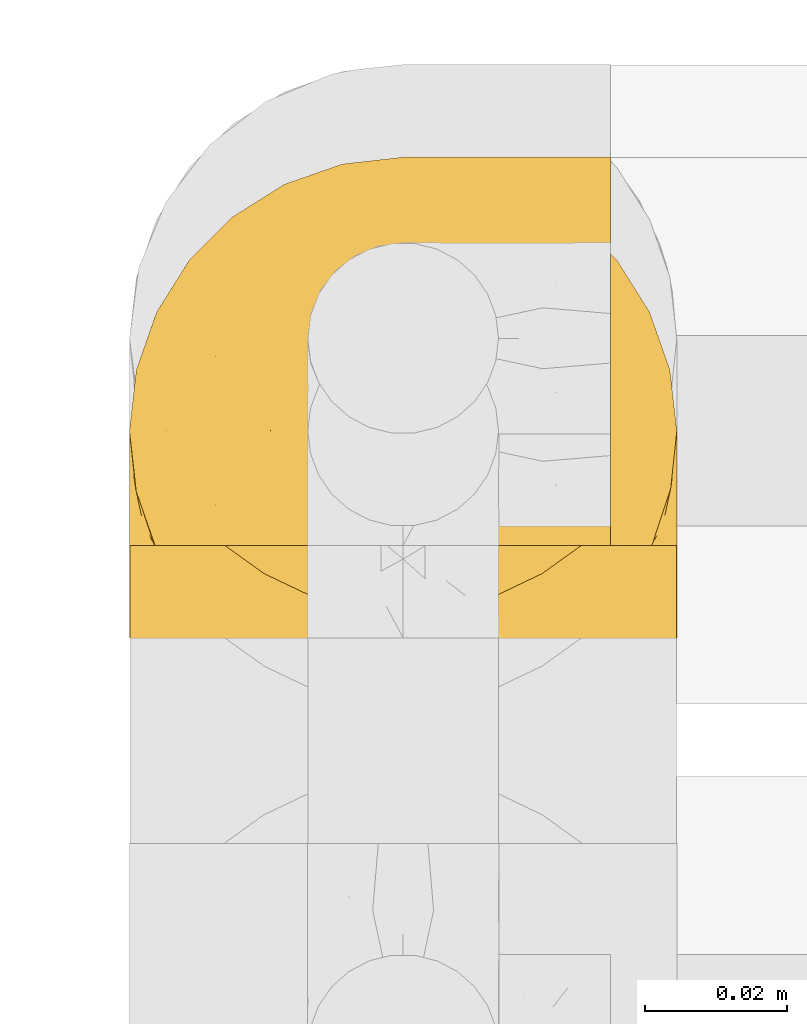
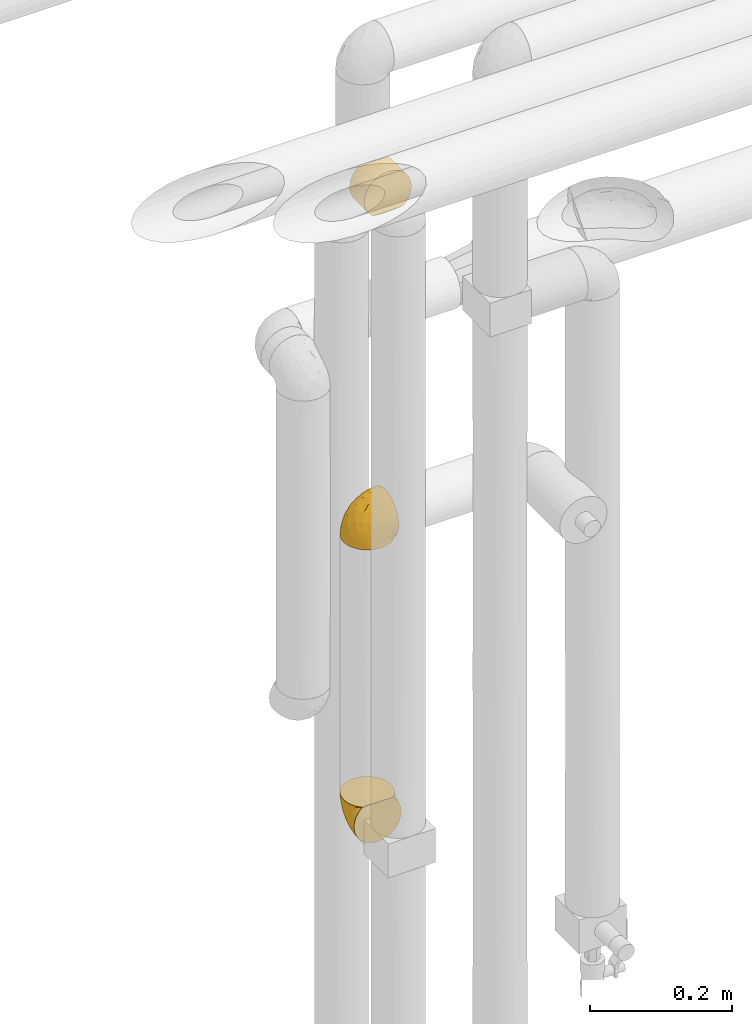
# One storey, part 327 of 827: 3 coverings.
"""IFC2X3 building model written with IfcOpenShell, lengths in millimetres."""

from ifc_helpers import new_model, entity, si_unit, converted_unit, derived_unit, direction, frame, origin, place, context, subcontext, project, spatial, faceted_brep, element, save


model = new_model("IFC2X3")

# Units and contexts
model_context = context("Model", 3, precision=0.01, world=origin(), true_north=direction((6.12303176911189e-17, 1.0)))
body_context = subcontext(model_context, "Body", "Model", "MODEL_VIEW")
ifc_project = project(units=[si_unit("LENGTHUNIT", "METRE", prefix="MILLI"), si_unit("AREAUNIT", "SQUARE_METRE"), si_unit("VOLUMEUNIT", "CUBIC_METRE"), converted_unit("PLANEANGLEUNIT", "DEGREE", entity("IfcRatioMeasure", 0.0174532925199433), si_unit("PLANEANGLEUNIT", "RADIAN"), dimensions=[0, 0, 0, 0, 0, 0, 0]), si_unit("MASSUNIT", "GRAM", prefix="KILO"), derived_unit("MASSDENSITYUNIT", [(si_unit("MASSUNIT", "GRAM", prefix="KILO"), 1), (si_unit("LENGTHUNIT", "METRE"), -3)]), derived_unit("MOMENTOFINERTIAUNIT", [(si_unit("LENGTHUNIT", "METRE"), 4)]), si_unit("TIMEUNIT", "SECOND"), si_unit("FREQUENCYUNIT", "HERTZ"), si_unit("THERMODYNAMICTEMPERATUREUNIT", "DEGREE_CELSIUS"), derived_unit("THERMALTRANSMITTANCEUNIT", [(si_unit("MASSUNIT", "GRAM", prefix="KILO"), 1), (si_unit("THERMODYNAMICTEMPERATUREUNIT", "KELVIN"), -1), (si_unit("TIMEUNIT", "SECOND"), -3)]), derived_unit("VOLUMETRICFLOWRATEUNIT", [(si_unit("LENGTHUNIT", "METRE"), 3), (si_unit("TIMEUNIT", "SECOND"), -1)]), derived_unit("MASSFLOWRATEUNIT", [(si_unit("MASSUNIT", "GRAM", prefix="KILO"), 1), (si_unit("TIMEUNIT", "SECOND"), -1)]), derived_unit("ROTATIONALFREQUENCYUNIT", [(si_unit("TIMEUNIT", "SECOND"), -1)]), si_unit("ELECTRICCURRENTUNIT", "AMPERE"), si_unit("ELECTRICVOLTAGEUNIT", "VOLT"), si_unit("POWERUNIT", "WATT"), si_unit("FORCEUNIT", "NEWTON", prefix="KILO"), si_unit("ILLUMINANCEUNIT", "LUX"), si_unit("LUMINOUSFLUXUNIT", "LUMEN"), si_unit("LUMINOUSINTENSITYUNIT", "CANDELA"), derived_unit("USERDEFINED", [(si_unit("MASSUNIT", "GRAM", prefix="KILO"), -1), (si_unit("LENGTHUNIT", "METRE"), -2), (si_unit("TIMEUNIT", "SECOND"), 3), (si_unit("LUMINOUSFLUXUNIT", "LUMEN"), 1)]), derived_unit("LINEARVELOCITYUNIT", [(si_unit("LENGTHUNIT", "METRE"), 1), (si_unit("TIMEUNIT", "SECOND"), -1)]), si_unit("PRESSUREUNIT", "PASCAL"), derived_unit("USERDEFINED", [(si_unit("LENGTHUNIT", "METRE"), -2), (si_unit("MASSUNIT", "GRAM", prefix="KILO"), 1), (si_unit("TIMEUNIT", "SECOND"), -2)]), derived_unit("LINEARFORCEUNIT", [(si_unit("MASSUNIT", "GRAM", prefix="KILO"), 1), (si_unit("LENGTHUNIT", "METRE"), 1), (si_unit("TIMEUNIT", "SECOND"), -2), (si_unit("LENGTHUNIT", "METRE"), -1)]), derived_unit("PLANARFORCEUNIT", [(si_unit("MASSUNIT", "GRAM", prefix="KILO"), 1), (si_unit("LENGTHUNIT", "METRE"), 1), (si_unit("TIMEUNIT", "SECOND"), -2), (si_unit("LENGTHUNIT", "METRE"), -2)])], contexts=[model_context])

# Site, building, storey
site_placement = place(None, origin())
site = spatial("IfcSite", under=ifc_project, at=site_placement, CompositionType="ELEMENT")
building_placement = place(site_placement, origin())
building = spatial("IfcBuilding", under=site, at=building_placement, CompositionType="ELEMENT")
storey_placement = place(building_placement, frame((0.0, 0.0, 28200.0)))
storey = spatial("IfcBuildingStorey", under=building, at=storey_placement, Name="08", CompositionType="ELEMENT", Elevation=28200.0)

# Coverings
covering_1_placement = place(storey_placement, frame((34485.34, 18381.86, 2179.3)))
element("IfcCovering", 1, at=covering_1_placement, inside=storey, Name=":ADSK_", ObjectType=":ADSK_", PredefinedType="INSULATION", context=body_context, shape_type="Brep", body=[
    faceted_brep([(23.36, 5.41, 1.6), (16.07, 9.99, 1.6), (9.98, 16.08, 1.6), (5.4, 23.37, 1.6), (2.56, 31.49, 1.6), (1.6, 40.05, 1.6), (2.56, 48.61, 1.6), (5.41, 56.73, 1.6), (9.99, 64.02, 1.6), (16.08, 70.11, 1.6), (23.37, 74.69, 1.6), (31.49, 77.53, 1.6), (40.05, 78.5, 1.6), (48.15, 77.63, 1.6), (55.88, 75.08, 1.6), (62.9, 70.97, 1.6), (68.89, 65.47, 1.6), (68.89, 63.27, 1.6), (68.89, 61.53, 1.6), (68.89, 59.57, 1.6), (68.89, 57.6, 1.6), (68.89, 55.63, 1.6), (68.89, 53.67, 1.6), (68.89, 51.7, 1.6), (68.89, 49.73, 1.6), (68.89, 47.54, 1.6), (68.89, 45.34, 1.6), (68.89, 43.15, 1.6), (68.89, 40.96, 1.6), (68.89, 38.76, 1.6), (68.89, 36.57, 1.6), (68.89, 34.37, 1.6), (68.89, 32.18, 1.6), (68.89, 29.98, 1.6), (68.89, 27.79, 1.6), (68.89, 25.6, 1.6), (68.89, 23.4, 1.6), (68.89, 21.21, 1.6), (68.89, 19.01, 1.6), (68.89, 16.82, 1.6), (68.89, 14.62, 1.6), (62.89, 9.12, 1.6), (55.86, 5.0, 1.6), (48.13, 2.46, 1.6), (40.05, 1.6, 1.6), (31.49, 2.56, 1.6), (69.15, 65.47, 1.85), (69.15, 70.97, 7.85), (69.15, 75.09, 14.87), (69.15, 77.63, 22.6), (69.15, 78.5, 30.7), (69.15, 77.19, 40.65), (69.15, 73.34, 49.92), (69.15, 67.23, 57.88), (69.15, 59.27, 63.99), (69.15, 50.0, 67.84), (69.15, 40.05, 69.15), (69.15, 30.09, 67.84), (69.15, 20.82, 63.99), (69.15, 12.86, 57.88), (69.15, 6.75, 49.92), (69.15, 2.91, 40.65), (69.15, 1.6, 30.7), (69.15, 2.46, 22.6), (69.15, 5.0, 14.87), (69.15, 9.12, 7.85), (69.15, 14.62, 1.85), (69.15, 16.82, 1.85), (69.15, 17.8, 1.85), (69.15, 19.39, 1.85), (69.15, 20.98, 1.85), (69.15, 22.57, 1.85), (69.15, 24.16, 1.85), (69.15, 25.75, 1.85), (69.15, 27.33, 1.85), (69.15, 28.92, 1.85), (69.15, 30.51, 1.85), (69.15, 32.1, 1.85), (69.15, 33.69, 1.85), (69.15, 35.28, 1.85), (69.15, 36.87, 1.85), (69.15, 38.46, 1.85), (69.15, 40.05, 1.85), (69.15, 41.63, 1.85), (69.15, 43.22, 1.85), (69.15, 44.81, 1.85), (69.15, 46.4, 1.85), (69.15, 47.99, 1.85), (69.15, 49.58, 1.85), (69.15, 51.17, 1.85), (69.15, 52.76, 1.85), (69.15, 54.72, 1.85), (69.15, 56.69, 1.85), (69.15, 58.88, 1.85), (69.15, 61.08, 1.85), (69.15, 63.27, 1.85), (68.96, 37.77, 1.77), (68.97, 36.07, 1.78), (68.97, 32.96, 1.77), (68.97, 31.36, 1.77), (68.95, 56.52, 1.76), (68.96, 54.96, 1.77), (68.98, 18.75, 1.79), (68.97, 58.07, 1.78), (68.97, 50.37, 1.78), (68.98, 23.36, 1.78), (68.97, 24.95, 1.78), (68.97, 42.43, 1.78), (68.94, 15.97, 1.74), (68.98, 51.96, 1.78), (68.98, 53.47, 1.78), (68.96, 48.63, 1.77), (68.97, 63.93, 1.78), (68.98, 40.93, 1.78), (68.98, 29.72, 1.78), (68.97, 62.4, 1.77), (68.96, 60.92, 1.77), (68.97, 17.31, 1.77), (68.97, 21.74, 1.78), (68.98, 34.56, 1.78), (68.96, 20.18, 1.77), (68.97, 14.62, 1.77), (68.94, 14.62, 1.72), (68.92, 14.62, 1.66), (68.97, 65.47, 1.77), (69.02, 65.47, 1.8), (69.08, 65.47, 1.82), (68.98, 59.5, 1.79), (68.97, 47.1, 1.78), (68.98, 45.61, 1.79), (68.97, 28.18, 1.78), (69.08, 14.62, 1.82), (69.02, 14.62, 1.8), (68.96, 26.61, 1.76), (68.92, 65.47, 1.66), (68.94, 65.47, 1.72), (68.97, 39.32, 1.78), (68.96, 44.12, 1.77), (67.02, 72.26, 9.41), (63.33, 76.57, 17.65), (64.61, 71.77, 7.41), (49.27, 78.5, 21.47), (51.4, 77.9, 15.21), (43.94, 78.5, 16.15), (61.87, 78.5, 28.75), (61.54, 75.52, 13.67), (57.95, 76.13, 12.79), (56.12, 77.81, 19.18), (65.41, 72.4, 9.04), (53.1, 76.56, 7.41), (63.04, 71.77, 5.74), (61.33, 72.25, 3.72), (41.99, 78.5, 8.87), (54.6, 78.5, 26.8), (56.6, 75.75, 9.53), (41.58, 78.5, 7.34), (61.54, 75.57, 44.74), (28.67, 76.34, 12.03), (58.75, 77.64, 37.26), (46.12, 63.45, 56.57), (55.56, 70.55, 52.31), (42.09, 71.02, 45.87), (17.15, 66.15, 25.73), (12.68, 60.51, 26.34), (20.17, 63.72, 35.21), (52.38, 75.57, 42.07), (23.76, 72.61, 21.49), (34.7, 76.83, 22.52), (20.5, 72.61, 11.02), (14.64, 67.24, 15.64), (49.4, 47.19, 65.49), (52.34, 54.76, 63.99), (58.67, 63.45, 60.27), (5.82, 52.75, 17.92), (30.64, 53.89, 53.93), (26.66, 46.73, 53.36), (37.53, 48.67, 60.18), (41.11, 55.34, 59.54), (21.38, 40.05, 49.36), (13.72, 50.46, 37.63), (6.74, 40.05, 27.45), (14.06, 40.05, 38.4), (41.77, 77.74, 26.02), (51.58, 77.66, 34.22), (16.28, 57.43, 36.59), (4.3, 40.05, 15.2), (8.62, 60.51, 13.32), (25.26, 60.1, 45.25), (21.47, 51.88, 46.78), (33.37, 72.59, 35.9), (41.35, 76.05, 33.87), (55.54, 40.05, 66.44), (35.17, 63.95, 50.09), (29.04, 67.24, 41.08), (24.34, 69.62, 31.14), (29.33, 73.6, 28.19), (43.3, 40.05, 64.0), (32.34, 40.05, 56.68), (49.41, 32.72, 65.46), (41.58, 1.6, 7.34), (28.66, 3.75, 12.03), (13.7, 29.63, 37.61), (27.85, 27.18, 52.22), (5.82, 27.35, 17.91), (12.67, 19.59, 26.34), (19.45, 12.86, 28.05), (14.63, 12.86, 15.64), (23.75, 7.49, 21.48), (48.85, 9.54, 50.02), (54.13, 16.64, 59.28), (37.84, 17.48, 53.05), (55.15, 2.33, 35.39), (54.6, 1.6, 26.8), (61.87, 1.6, 28.75), (37.91, 8.17, 41.4), (50.18, 4.3, 40.48), (57.58, 26.94, 65.81), (20.83, 20.75, 41.02), (59.91, 9.54, 53.28), (57.75, 4.52, 43.9), (20.49, 7.49, 11.01), (41.99, 1.6, 8.87), (43.94, 1.6, 16.15), (8.61, 19.59, 13.31), (34.7, 3.27, 22.54), (42.64, 2.45, 27.68), (49.27, 1.6, 21.47), (36.94, 31.21, 59.8), (45.72, 25.33, 61.82), (62.29, 2.29, 37.3), (29.01, 12.86, 41.07), (31.47, 6.89, 32.24), (49.29, 2.23, 31.68), (37.18, 12.43, 47.4), (43.45, 4.1, 35.77), (63.33, 3.53, 17.65), (67.23, 6.88, 11.06), (66.07, 8.16, 8.55), (65.22, 9.02, 6.63), (61.99, 5.0, 12.77), (57.95, 3.96, 12.79), (53.09, 3.52, 7.41), (56.84, 2.4, 18.97), (61.33, 7.83, 3.72), (63.06, 8.32, 5.76), (51.41, 2.19, 15.21), (56.61, 4.34, 9.52)], [[[0, 1, 2, 3, 4, 5, 6, 7, 8, 9, 10, 11, 12, 13, 14, 15, 16, 17, 18, 19, 20, 21, 22, 23, 24, 25, 26, 27, 28, 29, 30, 31, 32, 33, 34, 35, 36, 37, 38, 39, 40, 41, 42, 43, 44, 45]], [[46, 47, 48, 49, 50, 51, 52, 53, 54, 55, 56, 57, 58, 59, 60, 61, 62, 63, 64, 65, 66, 67, 68, 69, 70, 71, 72, 73, 74, 75, 76, 77, 78, 79, 80, 81, 82, 83, 84, 85, 86, 87, 88, 89, 90, 91, 92, 93, 94, 95]], [[96, 97, 30]], [[98, 77, 99]], [[100, 101, 21]], [[69, 68, 102]], [[20, 19, 103]], [[24, 23, 104]], [[20, 103, 100]], [[72, 105, 106]], [[84, 83, 107]], [[89, 88, 104]], [[108, 67, 66]], [[109, 110, 90]], [[111, 25, 24]], [[112, 17, 16]], [[82, 113, 83]], [[109, 23, 22]], [[114, 76, 75]], [[105, 36, 106]], [[104, 111, 24]], [[18, 115, 116]], [[97, 96, 80]], [[67, 108, 117]], [[105, 71, 118]], [[31, 97, 119]], [[102, 120, 69]], [[108, 121, 122, 123, 40]], [[112, 95, 115]], [[17, 115, 18]], [[94, 116, 115]], [[117, 68, 67]], [[38, 117, 39]], [[112, 124, 125, 126, 46]], [[17, 112, 115]], [[70, 120, 118]], [[39, 117, 108]], [[120, 38, 37]], [[120, 37, 118]], [[120, 70, 69]], [[116, 94, 127]], [[128, 86, 129]], [[117, 38, 102]], [[74, 130, 75]], [[99, 33, 32]], [[115, 95, 94]], [[39, 108, 40]], [[108, 66, 131, 132, 121]], [[105, 72, 71]], [[118, 37, 36]], [[71, 70, 118]], [[35, 106, 36]], [[36, 105, 118]], [[35, 133, 106]], [[74, 73, 133]], [[106, 133, 73]], [[99, 114, 33]], [[133, 35, 34]], [[73, 72, 106]], [[95, 112, 46]], [[112, 16, 134, 135, 124]], [[130, 114, 75]], [[99, 76, 114]], [[114, 130, 33]], [[34, 33, 130]], [[78, 77, 98]], [[98, 119, 78]], [[130, 133, 34]], [[133, 130, 74]], [[79, 97, 80]], [[98, 99, 32]], [[98, 32, 31]], [[77, 76, 99]], [[97, 79, 119]], [[136, 96, 29]], [[30, 97, 31]], [[136, 29, 28]], [[81, 80, 96]], [[29, 96, 30]], [[31, 119, 98]], [[119, 79, 78]], [[96, 136, 81]], [[82, 81, 136]], [[113, 107, 83]], [[84, 107, 137]], [[107, 27, 137]], [[113, 28, 107]], [[27, 107, 28]], [[85, 84, 137]], [[137, 27, 26]], [[113, 136, 28]], [[136, 113, 82]], [[109, 89, 104]], [[86, 85, 129]], [[89, 109, 90]], [[111, 87, 128]], [[26, 129, 137]], [[88, 111, 104]], [[25, 111, 128]], [[22, 110, 109]], [[23, 109, 104]], [[110, 91, 90]], [[100, 92, 101]], [[110, 22, 101]], [[91, 110, 101]], [[116, 19, 18]], [[111, 88, 87]], [[127, 103, 19]], [[25, 128, 26]], [[86, 128, 87]], [[128, 129, 26]], [[137, 129, 85]], [[120, 102, 38]], [[117, 102, 68]], [[91, 101, 92]], [[21, 101, 22]], [[93, 92, 103]], [[100, 21, 20]], [[100, 103, 92]], [[127, 93, 103]], [[93, 127, 94]], [[116, 127, 19]], [[126, 138, 47]], [[48, 138, 139]], [[140, 125, 124]], [[141, 142, 143]], [[144, 49, 139]], [[145, 140, 146]], [[48, 139, 49]], [[139, 145, 147]], [[144, 50, 49]], [[126, 125, 148]], [[14, 13, 149]], [[150, 146, 140]], [[148, 140, 145]], [[151, 150, 135]], [[151, 14, 149]], [[16, 15, 134]], [[13, 152, 149]], [[124, 150, 140]], [[141, 147, 142]], [[14, 151, 15]], [[15, 151, 134]], [[47, 46, 126]], [[139, 153, 144]], [[138, 48, 47]], [[125, 140, 148]], [[135, 134, 151]], [[146, 154, 142]], [[145, 146, 147]], [[148, 139, 138]], [[147, 141, 153]], [[147, 146, 142]], [[139, 147, 153]], [[139, 148, 145]], [[148, 138, 126]], [[154, 146, 150]], [[149, 143, 142]], [[151, 154, 150]], [[149, 142, 154]], [[13, 12, 155, 152]], [[152, 143, 149]], [[151, 149, 154]], [[150, 124, 135]], [[51, 156, 52]], [[155, 11, 157]], [[50, 144, 158]], [[159, 160, 161]], [[162, 163, 164]], [[158, 165, 156]], [[157, 166, 167]], [[166, 168, 169]], [[170, 55, 171]], [[161, 160, 165]], [[172, 54, 53]], [[160, 53, 52]], [[173, 7, 6]], [[54, 172, 171]], [[174, 175, 176]], [[170, 177, 176]], [[167, 143, 157]], [[178, 179, 180, 181]], [[157, 11, 10]], [[141, 182, 183]], [[160, 52, 156]], [[173, 179, 184]], [[8, 169, 9]], [[173, 6, 185]], [[155, 12, 11]], [[8, 7, 186]], [[162, 169, 163]], [[187, 184, 188]], [[180, 173, 185]], [[10, 168, 157]], [[54, 171, 55]], [[186, 173, 163]], [[157, 143, 152, 155]], [[189, 161, 190]], [[179, 173, 180]], [[9, 168, 10]], [[186, 169, 8]], [[187, 164, 184]], [[144, 183, 158]], [[172, 160, 159]], [[177, 174, 176]], [[55, 170, 191]], [[187, 192, 193]], [[183, 182, 190]], [[166, 194, 195]], [[167, 190, 182]], [[6, 5, 185]], [[173, 186, 7]], [[169, 186, 163]], [[169, 168, 9]], [[157, 168, 166]], [[190, 161, 165]], [[161, 193, 192]], [[183, 165, 158]], [[194, 189, 195]], [[191, 170, 196]], [[191, 56, 55]], [[175, 178, 197]], [[197, 196, 176]], [[170, 176, 196]], [[188, 175, 174]], [[197, 176, 175]], [[177, 170, 171]], [[171, 159, 177]], [[192, 177, 159]], [[187, 188, 174]], [[188, 179, 178]], [[174, 177, 192]], [[164, 187, 193]], [[174, 192, 187]], [[161, 192, 159]], [[194, 164, 193]], [[184, 164, 163]], [[189, 194, 193]], [[162, 166, 169]], [[161, 189, 193]], [[195, 190, 167]], [[173, 184, 163]], [[184, 179, 188]], [[164, 194, 162]], [[166, 162, 194]], [[190, 195, 189]], [[167, 182, 143]], [[167, 166, 195]], [[160, 172, 53]], [[171, 172, 159]], [[51, 50, 158]], [[160, 156, 165]], [[51, 158, 156]], [[183, 144, 153]], [[141, 183, 153]], [[190, 165, 183]], [[178, 175, 188]], [[143, 182, 141]], [[198, 191, 196]], [[45, 199, 200]], [[178, 201, 202]], [[201, 203, 204]], [[205, 206, 207]], [[57, 56, 191]], [[4, 185, 5]], [[208, 209, 210]], [[211, 212, 213]], [[208, 214, 215]], [[216, 209, 58]], [[201, 217, 202]], [[59, 218, 60]], [[60, 218, 219]], [[201, 178, 181, 180]], [[1, 0, 220]], [[201, 180, 203]], [[200, 199, 221, 222]], [[203, 185, 4]], [[3, 203, 4]], [[2, 1, 206]], [[217, 210, 202]], [[58, 209, 59]], [[3, 223, 203]], [[207, 220, 200]], [[204, 223, 206]], [[205, 204, 206]], [[207, 200, 224]], [[200, 222, 224]], [[206, 223, 2]], [[225, 222, 226]], [[220, 206, 1]], [[60, 219, 61]], [[57, 198, 216]], [[227, 202, 228]], [[3, 2, 223]], [[45, 44, 199]], [[0, 45, 200]], [[219, 211, 229]], [[230, 231, 214]], [[231, 207, 224]], [[210, 209, 228]], [[218, 209, 208]], [[226, 232, 225]], [[231, 230, 205]], [[202, 210, 228]], [[233, 230, 214]], [[227, 228, 198]], [[201, 204, 217]], [[211, 232, 212]], [[180, 185, 203]], [[61, 229, 62]], [[203, 223, 204]], [[200, 220, 0]], [[206, 220, 207]], [[225, 231, 224]], [[232, 226, 212]], [[214, 231, 234]], [[197, 227, 196]], [[191, 198, 57]], [[198, 228, 216]], [[202, 197, 178]], [[196, 227, 198]], [[197, 202, 227]], [[209, 216, 228]], [[58, 57, 216]], [[229, 211, 213]], [[215, 211, 219]], [[205, 217, 204]], [[210, 217, 230]], [[62, 229, 213]], [[219, 229, 61]], [[231, 205, 207]], [[217, 205, 230]], [[215, 214, 234]], [[233, 208, 210]], [[209, 218, 59]], [[219, 218, 208]], [[208, 215, 219]], [[232, 215, 234]], [[215, 232, 211]], [[232, 234, 225]], [[231, 225, 234]], [[222, 225, 224]], [[208, 233, 214]], [[210, 230, 233]], [[63, 213, 235]], [[213, 212, 235]], [[213, 63, 62]], [[236, 235, 237]], [[237, 132, 131]], [[235, 236, 64]], [[238, 239, 240]], [[63, 235, 64]], [[131, 66, 65]], [[236, 131, 65]], [[241, 221, 43]], [[236, 65, 64]], [[238, 121, 132]], [[42, 241, 43]], [[240, 239, 242]], [[41, 123, 243]], [[43, 221, 199, 44]], [[243, 122, 244]], [[226, 245, 242]], [[240, 242, 245]], [[121, 238, 244]], [[41, 40, 123]], [[132, 237, 238]], [[243, 42, 41]], [[131, 236, 237]], [[239, 238, 237]], [[244, 238, 240]], [[246, 240, 245]], [[246, 243, 244]], [[237, 235, 239]], [[242, 235, 212]], [[235, 242, 239]], [[222, 245, 226]], [[242, 212, 226]], [[222, 241, 245]], [[240, 246, 244]], [[245, 241, 246]], [[243, 246, 241]], [[241, 222, 221]], [[42, 243, 241]], [[122, 243, 123]], [[122, 121, 244]]]),
])
covering_2_placement = place(storey_placement, frame((34485.34, 18391.21, 1669.95)))
element("IfcCovering", 2, at=covering_2_placement, inside=storey, Name=":ADSK_", ObjectType=":ADSK_", PredefinedType="INSULATION", context=body_context, shape_type="Brep", body=[
    faceted_brep([(74.68, 47.38, 69.15), (70.1, 54.67, 69.15), (64.01, 60.76, 69.15), (56.72, 65.34, 69.15), (48.6, 68.18, 69.15), (40.05, 69.15, 69.15), (31.49, 68.18, 69.15), (23.36, 65.33, 69.15), (16.07, 60.75, 69.15), (9.98, 54.66, 69.15), (5.4, 47.37, 69.15), (2.56, 39.25, 69.15), (1.6, 30.7, 69.15), (2.46, 22.59, 69.15), (5.01, 14.86, 69.15), (9.13, 7.84, 69.15), (14.62, 1.85, 69.15), (16.82, 1.85, 69.15), (18.56, 1.85, 69.15), (20.52, 1.85, 69.15), (22.49, 1.85, 69.15), (24.46, 1.85, 69.15), (26.42, 1.85, 69.15), (28.39, 1.85, 69.15), (30.36, 1.85, 69.15), (32.55, 1.85, 69.15), (34.75, 1.85, 69.15), (36.94, 1.85, 69.15), (39.13, 1.85, 69.15), (41.33, 1.85, 69.15), (43.52, 1.85, 69.15), (45.72, 1.85, 69.15), (47.91, 1.85, 69.15), (50.11, 1.85, 69.15), (52.3, 1.85, 69.15), (54.49, 1.85, 69.15), (56.69, 1.85, 69.15), (58.88, 1.85, 69.15), (61.08, 1.85, 69.15), (63.27, 1.85, 69.15), (65.47, 1.85, 69.15), (70.97, 7.85, 69.15), (75.09, 14.88, 69.15), (77.64, 22.61, 69.15), (78.5, 30.7, 69.15), (77.53, 39.26, 69.15), (14.62, 1.6, 68.89), (9.12, 1.6, 62.89), (5.0, 1.6, 55.87), (2.46, 1.6, 48.14), (1.6, 1.6, 40.05), (2.91, 1.6, 30.09), (6.75, 1.6, 20.82), (12.86, 1.6, 12.86), (20.82, 1.6, 6.75), (30.09, 1.6, 2.91), (40.05, 1.6, 1.6), (50.0, 1.6, 2.91), (59.27, 1.6, 6.75), (67.23, 1.6, 12.86), (73.34, 1.6, 20.82), (77.19, 1.6, 30.09), (78.5, 1.6, 40.05), (77.63, 1.6, 48.14), (75.09, 1.6, 55.87), (70.97, 1.6, 62.89), (65.47, 1.6, 68.89), (63.27, 1.6, 68.89), (62.29, 1.6, 68.89), (60.7, 1.6, 68.89), (59.11, 1.6, 68.89), (57.52, 1.6, 68.89), (55.93, 1.6, 68.89), (54.34, 1.6, 68.89), (52.76, 1.6, 68.89), (51.17, 1.6, 68.89), (49.58, 1.6, 68.89), (47.99, 1.6, 68.89), (46.4, 1.6, 68.89), (44.81, 1.6, 68.89), (43.22, 1.6, 68.89), (41.63, 1.6, 68.89), (40.05, 1.6, 68.89), (38.46, 1.6, 68.89), (36.87, 1.6, 68.89), (35.28, 1.6, 68.89), (33.69, 1.6, 68.89), (32.1, 1.6, 68.89), (30.51, 1.6, 68.89), (28.92, 1.6, 68.89), (27.33, 1.6, 68.89), (25.37, 1.6, 68.89), (23.4, 1.6, 68.89), (21.21, 1.6, 68.89), (19.01, 1.6, 68.89), (16.82, 1.6, 68.89), (42.32, 1.78, 68.97), (44.02, 1.77, 68.96), (47.13, 1.78, 68.97), (48.74, 1.77, 68.97), (23.57, 1.79, 68.98), (25.13, 1.78, 68.97), (61.34, 1.76, 68.96), (22.02, 1.77, 68.96), (29.72, 1.77, 68.96), (56.73, 1.76, 68.96), (55.14, 1.77, 68.96), (37.66, 1.77, 68.96), (64.12, 1.8, 69.0), (28.13, 1.76, 68.96), (26.62, 1.77, 68.96), (31.46, 1.78, 68.97), (16.16, 1.77, 68.96), (39.16, 1.77, 68.96), (50.37, 1.76, 68.96), (17.69, 1.77, 68.97), (19.17, 1.78, 68.97), (62.78, 1.77, 68.97), (58.35, 1.77, 68.96), (45.53, 1.77, 68.96), (59.91, 1.78, 68.97), (65.47, 1.77, 68.97), (65.47, 1.8, 69.02), (65.47, 1.82, 69.08), (14.62, 1.77, 68.97), (14.62, 1.72, 68.94), (14.62, 1.66, 68.92), (20.59, 1.76, 68.96), (32.99, 1.77, 68.96), (34.48, 1.76, 68.95), (51.91, 1.77, 68.96), (65.47, 1.66, 68.92), (65.47, 1.72, 68.94), (53.48, 1.78, 68.98), (14.62, 1.82, 69.08), (14.62, 1.8, 69.02), (40.77, 1.77, 68.96), (35.97, 1.78, 68.97), (7.84, 3.72, 61.33), (3.53, 7.41, 53.1), (8.32, 6.13, 63.33), (1.6, 21.47, 49.27), (2.19, 19.34, 55.53), (1.6, 26.8, 54.6), (1.6, 8.87, 41.99), (4.57, 9.2, 57.07), (3.96, 12.79, 57.95), (2.28, 14.62, 51.56), (7.69, 5.33, 61.7), (3.53, 17.64, 63.33), (8.32, 7.7, 65.0), (7.84, 9.41, 67.02), (1.6, 28.75, 61.87), (1.6, 16.15, 43.94), (4.34, 14.14, 61.21), (1.6, 29.16, 63.4), (4.52, 9.2, 26.0), (3.75, 42.07, 58.71), (2.45, 11.99, 33.48), (16.64, 24.62, 14.17), (9.54, 15.19, 18.43), (9.07, 28.65, 24.87), (13.94, 53.59, 45.01), (19.58, 58.06, 44.4), (16.37, 50.57, 35.53), (4.52, 18.36, 28.67), (7.49, 46.98, 49.25), (3.26, 36.04, 48.22), (7.49, 50.24, 59.72), (12.85, 56.1, 55.1), (32.9, 21.34, 5.25), (25.33, 18.4, 6.75), (16.64, 12.07, 10.47), (27.34, 64.92, 52.82), (26.2, 40.1, 16.81), (33.36, 44.08, 17.38), (31.42, 33.21, 10.56), (24.75, 29.63, 11.2), (40.05, 49.36, 21.38), (29.63, 57.02, 33.11), (40.05, 64.0, 43.3), (40.05, 56.68, 32.34), (2.35, 28.97, 44.72), (2.43, 19.16, 36.52), (22.66, 54.46, 34.15), (40.05, 66.44, 55.54), (19.58, 62.12, 57.42), (19.99, 45.49, 25.49), (28.21, 49.27, 23.96), (7.5, 37.37, 34.84), (4.04, 29.39, 36.87), (40.05, 15.2, 4.3), (16.14, 35.57, 20.65), (12.85, 41.7, 29.66), (10.47, 46.4, 39.6), (6.49, 41.41, 42.55), (40.05, 27.45, 6.74), (40.05, 38.4, 14.06), (47.37, 21.33, 5.28), (78.5, 29.16, 63.4), (76.34, 42.08, 58.71), (50.46, 57.04, 33.13), (52.91, 42.89, 18.52), (52.74, 64.92, 52.83), (60.5, 58.07, 44.4), (67.23, 51.29, 42.69), (67.23, 56.11, 55.1), (72.6, 46.99, 49.26), (70.55, 21.89, 20.72), (63.45, 16.62, 11.46), (62.61, 32.9, 17.69), (77.76, 15.6, 35.35), (78.5, 16.15, 43.94), (78.5, 8.87, 41.99), (71.93, 32.83, 29.34), (75.79, 20.56, 30.26), (53.16, 13.16, 4.93), (59.34, 49.91, 29.72), (70.55, 10.83, 17.46), (75.57, 12.99, 26.84), (72.6, 50.25, 59.73), (78.5, 28.75, 61.87), (78.5, 26.8, 54.6), (60.5, 62.13, 57.43), (76.82, 36.04, 48.2), (77.64, 28.1, 43.06), (78.5, 21.47, 49.27), (48.88, 33.8, 10.94), (54.76, 25.02, 8.92), (77.8, 8.45, 33.44), (67.23, 41.73, 29.67), (73.2, 39.27, 38.5), (77.86, 21.46, 39.06), (67.66, 33.56, 23.35), (75.99, 27.29, 34.97), (76.57, 7.41, 53.1), (73.21, 3.51, 59.68), (71.93, 4.68, 62.19), (71.07, 5.52, 64.11), (75.09, 8.75, 57.97), (76.13, 12.79, 57.95), (76.57, 17.65, 63.33), (77.69, 13.9, 51.77), (72.26, 9.42, 67.02), (71.77, 7.68, 64.98), (77.9, 19.33, 55.53), (75.75, 14.13, 61.22)], [[[0, 1, 2, 3, 4, 5, 6, 7, 8, 9, 10, 11, 12, 13, 14, 15, 16, 17, 18, 19, 20, 21, 22, 23, 24, 25, 26, 27, 28, 29, 30, 31, 32, 33, 34, 35, 36, 37, 38, 39, 40, 41, 42, 43, 44, 45]], [[46, 47, 48, 49, 50, 51, 52, 53, 54, 55, 56, 57, 58, 59, 60, 61, 62, 63, 64, 65, 66, 67, 68, 69, 70, 71, 72, 73, 74, 75, 76, 77, 78, 79, 80, 81, 82, 83, 84, 85, 86, 87, 88, 89, 90, 91, 92, 93, 94, 95]], [[96, 97, 30]], [[98, 77, 99]], [[100, 101, 21]], [[69, 68, 102]], [[20, 19, 103]], [[24, 23, 104]], [[20, 103, 100]], [[72, 105, 106]], [[84, 83, 107]], [[89, 88, 104]], [[108, 67, 66]], [[109, 110, 90]], [[111, 25, 24]], [[112, 17, 16]], [[82, 113, 83]], [[109, 23, 22]], [[114, 76, 75]], [[105, 36, 106]], [[104, 111, 24]], [[18, 115, 116]], [[97, 96, 80]], [[67, 108, 117]], [[105, 71, 118]], [[31, 97, 119]], [[102, 120, 69]], [[108, 121, 122, 123, 40]], [[112, 95, 115]], [[17, 115, 18]], [[94, 116, 115]], [[117, 68, 67]], [[38, 117, 39]], [[112, 124, 125, 126, 46]], [[17, 112, 115]], [[70, 120, 118]], [[39, 117, 108]], [[120, 38, 37]], [[120, 37, 118]], [[120, 70, 69]], [[116, 94, 127]], [[128, 86, 129]], [[117, 38, 102]], [[74, 130, 75]], [[99, 33, 32]], [[115, 95, 94]], [[39, 108, 40]], [[108, 66, 131, 132, 121]], [[105, 72, 71]], [[118, 37, 36]], [[71, 70, 118]], [[35, 106, 36]], [[36, 105, 118]], [[35, 133, 106]], [[74, 73, 133]], [[106, 133, 73]], [[99, 114, 33]], [[133, 35, 34]], [[73, 72, 106]], [[95, 112, 46]], [[112, 16, 134, 135, 124]], [[130, 114, 75]], [[99, 76, 114]], [[114, 130, 33]], [[34, 33, 130]], [[78, 77, 98]], [[98, 119, 78]], [[130, 133, 34]], [[133, 130, 74]], [[79, 97, 80]], [[98, 99, 32]], [[98, 32, 31]], [[77, 76, 99]], [[97, 79, 119]], [[136, 96, 29]], [[30, 97, 31]], [[136, 29, 28]], [[81, 80, 96]], [[29, 96, 30]], [[31, 119, 98]], [[119, 79, 78]], [[96, 136, 81]], [[82, 81, 136]], [[113, 107, 83]], [[84, 107, 137]], [[107, 27, 137]], [[113, 28, 107]], [[27, 107, 28]], [[85, 84, 137]], [[137, 27, 26]], [[113, 136, 28]], [[136, 113, 82]], [[109, 89, 104]], [[86, 85, 129]], [[89, 109, 90]], [[111, 87, 128]], [[26, 129, 137]], [[88, 111, 104]], [[25, 111, 128]], [[22, 110, 109]], [[23, 109, 104]], [[110, 91, 90]], [[100, 92, 101]], [[110, 22, 101]], [[91, 110, 101]], [[116, 19, 18]], [[111, 88, 87]], [[127, 103, 19]], [[25, 128, 26]], [[86, 128, 87]], [[128, 129, 26]], [[137, 129, 85]], [[120, 102, 38]], [[117, 102, 68]], [[91, 101, 92]], [[21, 101, 22]], [[93, 92, 103]], [[100, 21, 20]], [[100, 103, 92]], [[127, 93, 103]], [[93, 127, 94]], [[116, 127, 19]], [[126, 138, 47]], [[48, 138, 139]], [[140, 125, 124]], [[141, 142, 143]], [[144, 49, 139]], [[145, 140, 146]], [[48, 139, 49]], [[139, 145, 147]], [[144, 50, 49]], [[126, 125, 148]], [[14, 13, 149]], [[150, 146, 140]], [[148, 140, 145]], [[151, 150, 135]], [[151, 14, 149]], [[16, 15, 134]], [[13, 152, 149]], [[124, 150, 140]], [[141, 147, 142]], [[14, 151, 15]], [[15, 151, 134]], [[47, 46, 126]], [[139, 153, 144]], [[138, 48, 47]], [[125, 140, 148]], [[135, 134, 151]], [[146, 154, 142]], [[145, 146, 147]], [[148, 139, 138]], [[147, 141, 153]], [[147, 146, 142]], [[139, 147, 153]], [[139, 148, 145]], [[148, 138, 126]], [[154, 146, 150]], [[149, 143, 142]], [[151, 154, 150]], [[149, 142, 154]], [[13, 12, 155, 152]], [[152, 143, 149]], [[151, 149, 154]], [[150, 124, 135]], [[51, 156, 52]], [[155, 11, 157]], [[50, 144, 158]], [[159, 160, 161]], [[162, 163, 164]], [[158, 165, 156]], [[157, 166, 167]], [[166, 168, 169]], [[170, 55, 171]], [[161, 160, 165]], [[172, 54, 53]], [[160, 53, 52]], [[173, 7, 6]], [[54, 172, 171]], [[174, 175, 176]], [[170, 177, 176]], [[167, 143, 157]], [[178, 179, 180, 181]], [[157, 11, 10]], [[141, 182, 183]], [[160, 52, 156]], [[173, 179, 184]], [[8, 169, 9]], [[173, 6, 185]], [[155, 12, 11]], [[8, 7, 186]], [[162, 169, 163]], [[187, 184, 188]], [[180, 173, 185]], [[10, 168, 157]], [[54, 171, 55]], [[186, 173, 163]], [[157, 143, 152, 155]], [[189, 161, 190]], [[179, 173, 180]], [[9, 168, 10]], [[186, 169, 8]], [[187, 164, 184]], [[144, 183, 158]], [[172, 160, 159]], [[177, 174, 176]], [[55, 170, 191]], [[187, 192, 193]], [[183, 182, 190]], [[166, 194, 195]], [[167, 190, 182]], [[6, 5, 185]], [[173, 186, 7]], [[169, 186, 163]], [[169, 168, 9]], [[157, 168, 166]], [[190, 161, 165]], [[161, 193, 192]], [[183, 165, 158]], [[194, 189, 195]], [[191, 170, 196]], [[191, 56, 55]], [[175, 178, 197]], [[197, 196, 176]], [[170, 176, 196]], [[188, 175, 174]], [[197, 176, 175]], [[177, 170, 171]], [[171, 159, 177]], [[192, 177, 159]], [[187, 188, 174]], [[188, 179, 178]], [[174, 177, 192]], [[164, 187, 193]], [[174, 192, 187]], [[161, 192, 159]], [[194, 164, 193]], [[184, 164, 163]], [[189, 194, 193]], [[162, 166, 169]], [[161, 189, 193]], [[195, 190, 167]], [[173, 184, 163]], [[184, 179, 188]], [[164, 194, 162]], [[166, 162, 194]], [[190, 195, 189]], [[167, 182, 143]], [[167, 166, 195]], [[160, 172, 53]], [[171, 172, 159]], [[51, 50, 158]], [[160, 156, 165]], [[51, 158, 156]], [[183, 144, 153]], [[141, 183, 153]], [[190, 165, 183]], [[178, 175, 188]], [[143, 182, 141]], [[198, 191, 196]], [[45, 199, 200]], [[178, 201, 202]], [[201, 203, 204]], [[205, 206, 207]], [[57, 56, 191]], [[4, 185, 5]], [[208, 209, 210]], [[211, 212, 213]], [[208, 214, 215]], [[216, 209, 58]], [[201, 217, 202]], [[59, 218, 60]], [[60, 218, 219]], [[201, 178, 181, 180]], [[1, 0, 220]], [[201, 180, 203]], [[200, 199, 221, 222]], [[203, 185, 4]], [[3, 203, 4]], [[2, 1, 206]], [[217, 210, 202]], [[58, 209, 59]], [[3, 223, 203]], [[207, 220, 200]], [[204, 223, 206]], [[205, 204, 206]], [[207, 200, 224]], [[200, 222, 224]], [[206, 223, 2]], [[225, 222, 226]], [[220, 206, 1]], [[60, 219, 61]], [[57, 198, 216]], [[227, 202, 228]], [[3, 2, 223]], [[45, 44, 199]], [[0, 45, 200]], [[219, 211, 229]], [[230, 231, 214]], [[231, 207, 224]], [[210, 209, 228]], [[218, 209, 208]], [[226, 232, 225]], [[231, 230, 205]], [[202, 210, 228]], [[233, 230, 214]], [[227, 228, 198]], [[201, 204, 217]], [[211, 232, 212]], [[180, 185, 203]], [[61, 229, 62]], [[203, 223, 204]], [[200, 220, 0]], [[206, 220, 207]], [[225, 231, 224]], [[232, 226, 212]], [[214, 231, 234]], [[197, 227, 196]], [[191, 198, 57]], [[198, 228, 216]], [[202, 197, 178]], [[196, 227, 198]], [[197, 202, 227]], [[209, 216, 228]], [[58, 57, 216]], [[229, 211, 213]], [[215, 211, 219]], [[205, 217, 204]], [[210, 217, 230]], [[62, 229, 213]], [[219, 229, 61]], [[231, 205, 207]], [[217, 205, 230]], [[215, 214, 234]], [[233, 208, 210]], [[209, 218, 59]], [[219, 218, 208]], [[208, 215, 219]], [[232, 215, 234]], [[215, 232, 211]], [[232, 234, 225]], [[231, 225, 234]], [[222, 225, 224]], [[208, 233, 214]], [[210, 230, 233]], [[63, 213, 235]], [[213, 212, 235]], [[213, 63, 62]], [[236, 235, 237]], [[237, 132, 131]], [[235, 236, 64]], [[238, 239, 240]], [[63, 235, 64]], [[131, 66, 65]], [[236, 131, 65]], [[241, 221, 43]], [[236, 65, 64]], [[238, 121, 132]], [[42, 241, 43]], [[240, 239, 242]], [[41, 123, 243]], [[43, 221, 199, 44]], [[243, 122, 244]], [[226, 245, 242]], [[240, 242, 245]], [[121, 238, 244]], [[41, 40, 123]], [[132, 237, 238]], [[243, 42, 41]], [[131, 236, 237]], [[239, 238, 237]], [[244, 238, 240]], [[246, 240, 245]], [[246, 243, 244]], [[237, 235, 239]], [[242, 235, 212]], [[235, 242, 239]], [[222, 245, 226]], [[242, 212, 226]], [[222, 241, 245]], [[240, 246, 244]], [[245, 241, 246]], [[243, 246, 241]], [[241, 222, 221]], [[42, 243, 241]], [[122, 243, 123]], [[122, 121, 244]]]),
])
covering_3_placement = place(storey_placement, frame((34485.39, 18362.42, 2760.0)))
element("IfcCovering", 3, at=covering_3_placement, inside=storey, Name=":ADSK_", ObjectType=":ADSK_", PredefinedType="INSULATION", context=body_context, shape_type="Brep", body=[
    faceted_brep([(9.31, 1.6, 16.91), (14.94, 1.6, 10.9), (65.05, 1.6, 10.9), (70.68, 1.6, 16.91), (74.9, 1.6, 23.98), (77.51, 1.6, 31.79), (78.4, 1.6, 40.0), (77.09, 1.6, 49.93), (73.25, 1.6, 59.2), (67.15, 1.6, 67.15), (59.2, 1.6, 73.25), (49.93, 1.6, 77.09), (40.0, 1.6, 78.4), (30.06, 1.6, 77.09), (20.8, 1.6, 73.25), (12.84, 1.6, 67.15), (6.74, 1.6, 59.2), (2.9, 1.6, 49.93), (1.6, 1.6, 40.0), (2.48, 1.6, 31.79), (5.09, 1.6, 23.98), (40.0, 43.39, 1.6), (30.06, 43.39, 2.9), (20.8, 43.39, 6.74), (12.84, 43.39, 12.84), (6.74, 43.39, 20.8), (2.9, 43.39, 30.06), (1.6, 43.39, 40.0), (2.48, 43.39, 48.2), (5.09, 43.39, 56.01), (9.31, 43.39, 63.08), (14.94, 43.39, 69.1), (65.05, 43.39, 69.1), (70.68, 43.39, 63.08), (74.9, 43.39, 56.01), (77.51, 43.39, 48.2), (78.4, 43.39, 40.0), (77.09, 43.39, 30.06), (73.25, 43.39, 20.8), (67.15, 43.39, 12.84), (59.2, 43.39, 6.74), (49.93, 43.39, 2.9), (26.63, 8.5, 4.0), (33.21, 10.29, 2.2), (40.0, 10.9, 1.6), (20.48, 5.57, 6.92), (46.78, 10.29, 2.2), (53.36, 8.5, 4.0), (59.51, 5.57, 6.92), (59.51, 39.42, 73.07), (53.36, 36.49, 76.0), (46.78, 34.7, 77.79), (40.0, 34.09, 78.4), (33.21, 34.7, 77.79), (26.63, 36.49, 76.0), (20.48, 39.42, 73.07)], [[[0, 1, 2, 3, 4, 5, 6, 7, 8, 9, 10, 11, 12, 13, 14, 15, 16, 17, 18, 19, 20]], [[21, 22, 23, 24, 25, 26, 27, 28, 29, 30, 31, 32, 33, 34, 35, 36, 37, 38, 39, 40, 41]], [[19, 27, 26]], [[25, 24, 0]], [[20, 26, 25]], [[18, 27, 19]], [[20, 19, 26]], [[0, 20, 25]], [[24, 1, 0]], [[42, 23, 22]], [[22, 21, 43]], [[44, 43, 21]], [[1, 24, 45]], [[43, 42, 22]], [[45, 23, 42]], [[45, 24, 23]], [[46, 44, 21]], [[46, 21, 41]], [[47, 41, 40]], [[47, 46, 41]], [[39, 2, 48]], [[47, 40, 48]], [[48, 40, 39]], [[3, 39, 38]], [[4, 38, 37]], [[5, 37, 36]], [[3, 38, 4]], [[4, 37, 5]], [[36, 6, 5]], [[39, 3, 2]], [[36, 35, 6]], [[34, 33, 8]], [[35, 34, 7]], [[7, 6, 35]], [[9, 8, 33]], [[7, 34, 8]], [[33, 32, 9]], [[49, 10, 9]], [[50, 51, 11]], [[49, 50, 10]], [[10, 50, 11]], [[12, 11, 51]], [[52, 12, 51]], [[49, 9, 32]], [[53, 54, 13]], [[14, 55, 15]], [[54, 55, 14]], [[52, 53, 12]], [[12, 53, 13]], [[54, 14, 13]], [[55, 31, 15]], [[16, 30, 29]], [[17, 29, 28]], [[18, 28, 27]], [[15, 30, 16]], [[16, 29, 17]], [[28, 18, 17]], [[30, 15, 31]], [[45, 42, 43, 44, 46, 47, 48, 2, 1]], [[55, 54, 53, 52, 51, 50, 49, 32, 31]]]),
])

save(model, "model.ifc")
